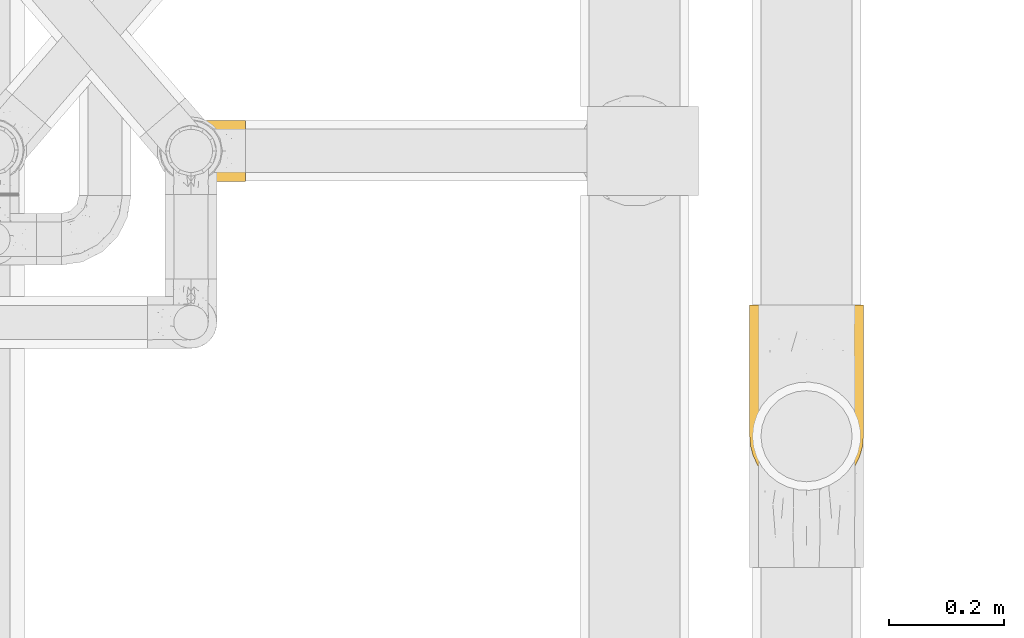
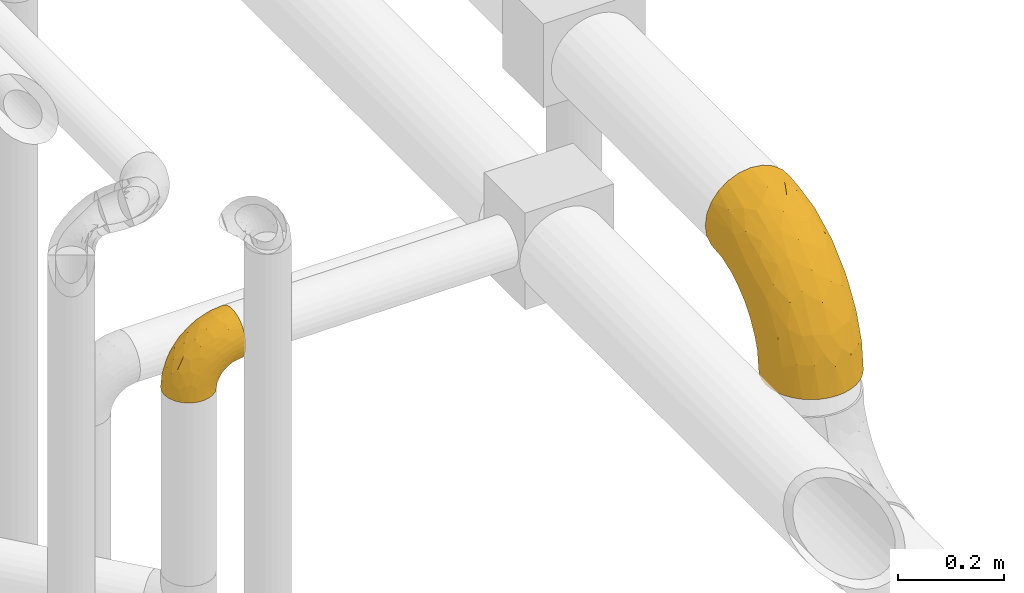
# One storey, part 197 of 827: 2 coverings.
"""IFC2X3 building model written with IfcOpenShell, lengths in millimetres."""

from ifc_helpers import new_model, entity, si_unit, converted_unit, derived_unit, direction, frame, origin, place, context, subcontext, project, spatial, faceted_brep, element, save


model = new_model("IFC2X3")

# Units and contexts
model_context = context("Model", 3, precision=0.01, world=origin(), true_north=direction((6.12303176911189e-17, 1.0)))
body_context = subcontext(model_context, "Body", "Model", "MODEL_VIEW")
ifc_project = project(units=[si_unit("LENGTHUNIT", "METRE", prefix="MILLI"), si_unit("AREAUNIT", "SQUARE_METRE"), si_unit("VOLUMEUNIT", "CUBIC_METRE"), converted_unit("PLANEANGLEUNIT", "DEGREE", entity("IfcRatioMeasure", 0.0174532925199433), si_unit("PLANEANGLEUNIT", "RADIAN"), dimensions=[0, 0, 0, 0, 0, 0, 0]), si_unit("MASSUNIT", "GRAM", prefix="KILO"), derived_unit("MASSDENSITYUNIT", [(si_unit("MASSUNIT", "GRAM", prefix="KILO"), 1), (si_unit("LENGTHUNIT", "METRE"), -3)]), derived_unit("MOMENTOFINERTIAUNIT", [(si_unit("LENGTHUNIT", "METRE"), 4)]), si_unit("TIMEUNIT", "SECOND"), si_unit("FREQUENCYUNIT", "HERTZ"), si_unit("THERMODYNAMICTEMPERATUREUNIT", "DEGREE_CELSIUS"), derived_unit("THERMALTRANSMITTANCEUNIT", [(si_unit("MASSUNIT", "GRAM", prefix="KILO"), 1), (si_unit("THERMODYNAMICTEMPERATUREUNIT", "KELVIN"), -1), (si_unit("TIMEUNIT", "SECOND"), -3)]), derived_unit("VOLUMETRICFLOWRATEUNIT", [(si_unit("LENGTHUNIT", "METRE"), 3), (si_unit("TIMEUNIT", "SECOND"), -1)]), derived_unit("MASSFLOWRATEUNIT", [(si_unit("MASSUNIT", "GRAM", prefix="KILO"), 1), (si_unit("TIMEUNIT", "SECOND"), -1)]), derived_unit("ROTATIONALFREQUENCYUNIT", [(si_unit("TIMEUNIT", "SECOND"), -1)]), si_unit("ELECTRICCURRENTUNIT", "AMPERE"), si_unit("ELECTRICVOLTAGEUNIT", "VOLT"), si_unit("POWERUNIT", "WATT"), si_unit("FORCEUNIT", "NEWTON", prefix="KILO"), si_unit("ILLUMINANCEUNIT", "LUX"), si_unit("LUMINOUSFLUXUNIT", "LUMEN"), si_unit("LUMINOUSINTENSITYUNIT", "CANDELA"), derived_unit("USERDEFINED", [(si_unit("MASSUNIT", "GRAM", prefix="KILO"), -1), (si_unit("LENGTHUNIT", "METRE"), -2), (si_unit("TIMEUNIT", "SECOND"), 3), (si_unit("LUMINOUSFLUXUNIT", "LUMEN"), 1)]), derived_unit("LINEARVELOCITYUNIT", [(si_unit("LENGTHUNIT", "METRE"), 1), (si_unit("TIMEUNIT", "SECOND"), -1)]), si_unit("PRESSUREUNIT", "PASCAL"), derived_unit("USERDEFINED", [(si_unit("LENGTHUNIT", "METRE"), -2), (si_unit("MASSUNIT", "GRAM", prefix="KILO"), 1), (si_unit("TIMEUNIT", "SECOND"), -2)]), derived_unit("LINEARFORCEUNIT", [(si_unit("MASSUNIT", "GRAM", prefix="KILO"), 1), (si_unit("LENGTHUNIT", "METRE"), 1), (si_unit("TIMEUNIT", "SECOND"), -2), (si_unit("LENGTHUNIT", "METRE"), -1)]), derived_unit("PLANARFORCEUNIT", [(si_unit("MASSUNIT", "GRAM", prefix="KILO"), 1), (si_unit("LENGTHUNIT", "METRE"), 1), (si_unit("TIMEUNIT", "SECOND"), -2), (si_unit("LENGTHUNIT", "METRE"), -2)])], contexts=[model_context])

# Site, building, storey
site_placement = place(None, origin())
site = spatial("IfcSite", under=ifc_project, at=site_placement, CompositionType="ELEMENT")
building_placement = place(site_placement, origin())
building = spatial("IfcBuilding", under=site, at=building_placement, CompositionType="ELEMENT")
storey_placement = place(building_placement, frame((0.0, 0.0, 28200.0)))
storey = spatial("IfcBuildingStorey", under=building, at=storey_placement, Name="08", CompositionType="ELEMENT", Elevation=28200.0)

# Coverings
covering_1_placement = place(storey_placement, frame((37947.55, 9481.97, 2769.4)))
element("IfcCovering", 1, at=covering_1_placement, inside=storey, Name=":ADSK_", ObjectType=":ADSK_", PredefinedType="INSULATION", context=body_context, shape_type="Brep", body=[
    faceted_brep([(193.91, 66.83, 1.6), (186.61, 51.17, 1.6), (176.69, 37.01, 1.6), (164.47, 24.79, 1.6), (150.31, 14.87, 1.6), (134.65, 7.57, 1.6), (117.95, 3.1, 1.6), (100.75, 1.6, 1.6), (83.53, 3.1, 1.6), (66.83, 7.58, 1.6), (51.17, 14.88, 1.6), (37.01, 24.8, 1.6), (24.79, 37.02, 1.6), (14.87, 51.18, 1.6), (7.57, 66.84, 1.6), (3.1, 83.54, 1.6), (1.6, 100.75, 1.6), (3.1, 117.96, 1.6), (7.58, 134.66, 1.6), (14.88, 150.32, 1.6), (24.8, 164.48, 1.6), (37.02, 176.7, 1.6), (51.18, 186.62, 1.6), (66.84, 193.92, 1.6), (83.54, 198.39, 1.6), (100.75, 199.9, 1.6), (117.96, 198.39, 1.6), (134.66, 193.91, 1.6), (150.32, 186.61, 1.6), (164.48, 176.69, 1.6), (176.7, 164.47, 1.6), (186.62, 150.31, 1.6), (193.92, 134.65, 1.6), (198.39, 117.95, 1.6), (199.9, 100.75, 1.6), (198.39, 83.53, 1.6), (75.08, 329.75, 134.82), (51.17, 329.75, 144.73), (30.64, 329.75, 160.49), (14.88, 329.75, 181.02), (4.97, 329.75, 204.93), (1.6, 329.75, 230.6), (4.97, 329.75, 256.26), (14.88, 329.75, 280.17), (30.64, 329.75, 300.7), (51.17, 329.75, 316.46), (75.08, 329.75, 326.37), (100.75, 329.75, 329.75), (126.41, 329.75, 326.37), (150.32, 329.75, 316.46), (170.85, 329.75, 300.7), (186.61, 329.75, 280.17), (196.52, 329.75, 256.26), (199.9, 329.75, 230.6), (196.52, 329.75, 204.93), (186.61, 329.75, 181.02), (170.85, 329.75, 160.49), (150.32, 329.75, 144.73), (126.41, 329.75, 134.82), (100.75, 329.75, 131.45), (126.94, 238.01, 312.99), (100.75, 265.73, 323.44), (100.75, 204.17, 304.77), (187.36, 58.91, 60.87), (132.83, 79.76, 205.84), (154.78, 132.21, 243.27), (134.44, 129.24, 253.87), (100.75, 97.71, 233.63), (197.98, 186.17, 204.27), (199.9, 150.71, 144.37), (199.9, 186.97, 180.63), (144.66, 183.03, 283.61), (123.78, 175.7, 288.26), (194.92, 78.89, 69.96), (175.07, 219.35, 274.76), (169.05, 164.59, 253.08), (182.08, 159.21, 230.82), (100.75, 147.43, 274.44), (157.56, 82.35, 188.83), (152.71, 44.46, 131.44), (171.44, 66.34, 142.07), (100.75, 56.9, 183.91), (140.35, 18.29, 74.6), (134.18, 35.26, 132.68), (119.92, 17.04, 94.72), (177.56, 280.46, 289.09), (158.32, 255.09, 302.19), (197.35, 236.53, 235.0), (100.75, 7.9, 65.61), (100.75, 26.57, 127.17), (189.12, 239.55, 260.27), (186.57, 77.16, 119.28), (142.79, 272.89, 315.28), (192.12, 179.84, 223.14), (186.94, 119.6, 183.59), (172.01, 119.08, 212.26), (196.08, 116.35, 143.44), (199.9, 230.39, 207.92), (199.9, 123.42, 100.95), (168.01, 36.91, 74.78), (161.18, 202.68, 281.73), (199.9, 278.79, 224.85), (199.9, 106.49, 52.55), (167.26, 279.85, 148.84), (180.73, 233.31, 142.09), (164.51, 248.07, 131.06), (195.96, 282.45, 197.3), (100.75, 204.32, 35.2), (129.57, 200.89, 38.85), (191.17, 221.48, 155.69), (193.22, 193.12, 138.22), (184.18, 206.15, 126.11), (197.62, 200.63, 164.53), (197.04, 234.54, 183.55), (194.43, 138.52, 47.01), (171.77, 216.73, 114.61), (142.9, 222.16, 90.01), (139.29, 244.97, 110.04), (156.26, 229.98, 109.35), (163.37, 186.39, 52.51), (100.75, 264.82, 114.05), (100.75, 296.14, 127.02), (124.57, 277.3, 123.55), (183.44, 294.68, 172.33), (148.24, 273.95, 132.14), (191.62, 174.02, 109.3), (177.88, 186.35, 86.6), (100.75, 217.29, 66.52), (141.27, 305.12, 137.9), (164.45, 198.94, 81.01), (119.01, 249.34, 105.71), (100.75, 237.93, 93.41), (147.34, 191.69, 32.55), (197.55, 152.36, 109.37), (189.81, 160.25, 76.79), (124.57, 224.79, 82.88), (149.54, 201.49, 64.13), (176.09, 170.92, 44.65), (185.6, 154.96, 33.7), (198.45, 174.17, 145.76), (197.84, 136.48, 81.0), (187.75, 253.47, 166.23), (36.99, 248.07, 131.06), (34.23, 279.84, 148.84), (53.25, 273.95, 132.14), (5.53, 282.45, 197.3), (1.6, 230.39, 207.92), (1.6, 278.79, 224.85), (82.48, 249.34, 105.71), (13.74, 253.46, 166.23), (18.05, 294.68, 172.33), (76.93, 224.79, 82.88), (20.76, 233.3, 142.08), (10.33, 221.48, 155.68), (3.36, 121.48, 31.12), (76.93, 277.3, 123.55), (71.93, 200.89, 38.84), (1.6, 123.42, 100.95), (7.06, 138.53, 47.02), (1.6, 106.49, 52.55), (48.1, 299.03, 143.28), (62.21, 244.97, 110.04), (58.59, 222.16, 90.01), (45.24, 230.0, 109.36), (23.62, 186.36, 86.6), (9.86, 174.01, 109.32), (17.31, 206.14, 126.08), (25.4, 170.94, 44.66), (11.69, 160.27, 76.81), (51.96, 201.5, 64.13), (1.6, 186.97, 180.63), (3.87, 200.62, 164.52), (3.05, 174.17, 145.75), (38.14, 186.4, 52.5), (37.05, 198.95, 81.01), (4.45, 234.52, 183.55), (54.17, 191.7, 32.55), (14.84, 155.33, 44.0), (5.35, 143.22, 79.09), (3.94, 152.35, 109.36), (8.28, 193.12, 138.22), (29.73, 216.74, 114.6), (1.6, 150.71, 144.37), (4.14, 236.53, 235.0), (3.51, 186.17, 204.27), (9.37, 179.84, 223.14), (74.55, 238.01, 312.99), (6.56, 78.9, 69.96), (14.92, 77.18, 119.29), (14.55, 119.62, 183.6), (5.41, 116.35, 143.44), (30.04, 66.35, 142.06), (67.05, 129.25, 253.88), (12.37, 239.55, 260.27), (57.97, 232.94, 304.98), (43.17, 255.09, 302.19), (56.83, 183.03, 283.61), (23.93, 280.45, 289.09), (26.42, 219.35, 274.76), (68.66, 79.76, 205.84), (67.31, 35.26, 132.69), (29.48, 119.08, 212.26), (43.93, 82.34, 188.81), (77.71, 175.7, 288.27), (39.51, 182.77, 271.11), (61.13, 18.3, 74.6), (46.71, 132.19, 243.26), (26.88, 166.31, 247.35), (33.47, 36.91, 74.77), (14.12, 58.92, 60.87), (81.56, 17.04, 94.72), (48.77, 44.46, 131.42)], [[[0, 1, 2, 3, 4, 5, 6, 7, 8, 9, 10, 11, 12, 13, 14, 15, 16, 17, 18, 19, 20, 21, 22, 23, 24, 25, 26, 27, 28, 29, 30, 31, 32, 33, 34, 35]], [[36, 37, 38, 39, 40, 41, 42, 43, 44, 45, 46, 47, 48, 49, 50, 51, 52, 53, 54, 55, 56, 57, 58, 59]], [[60, 61, 62]], [[61, 48, 47]], [[63, 2, 1]], [[64, 65, 66]], [[64, 66, 67]], [[68, 69, 70]], [[71, 72, 66]], [[73, 0, 35]], [[74, 75, 76]], [[77, 72, 62]], [[78, 79, 80]], [[64, 67, 81]], [[82, 83, 84]], [[51, 50, 85]], [[86, 50, 49]], [[53, 52, 87]], [[74, 85, 86]], [[88, 84, 89]], [[74, 76, 90]], [[73, 91, 63]], [[92, 48, 60]], [[93, 68, 87]], [[94, 95, 80]], [[94, 91, 96]], [[87, 68, 97]], [[96, 98, 69]], [[82, 99, 79]], [[99, 63, 80]], [[87, 90, 93]], [[78, 65, 64]], [[84, 6, 5]], [[99, 82, 3]], [[52, 90, 87]], [[82, 84, 5]], [[92, 86, 49]], [[3, 82, 4]], [[74, 100, 75]], [[88, 7, 6]], [[87, 97, 101]], [[99, 3, 2]], [[98, 96, 73]], [[98, 73, 102]], [[4, 82, 5]], [[34, 102, 35]], [[53, 87, 101]], [[84, 83, 89]], [[71, 86, 92]], [[80, 79, 99]], [[102, 73, 35]], [[96, 69, 68]], [[96, 91, 73]], [[73, 63, 0]], [[63, 99, 2]], [[52, 51, 90]], [[48, 61, 60]], [[83, 81, 89]], [[85, 90, 51]], [[65, 75, 100]], [[6, 84, 88]], [[82, 79, 83]], [[94, 80, 91]], [[78, 80, 95]], [[79, 64, 83]], [[81, 83, 64]], [[65, 78, 95]], [[64, 79, 78]], [[75, 65, 95]], [[65, 71, 66]], [[72, 71, 60]], [[67, 66, 77]], [[62, 72, 60]], [[77, 66, 72]], [[96, 93, 94]], [[76, 94, 93]], [[96, 68, 93]], [[97, 68, 70]], [[63, 91, 80]], [[0, 63, 1]], [[76, 75, 95]], [[74, 86, 100]], [[94, 76, 95]], [[76, 93, 90]], [[86, 71, 100]], [[65, 100, 71]], [[86, 85, 50]], [[90, 85, 74]], [[48, 92, 49]], [[71, 92, 60]], [[103, 104, 105]], [[54, 53, 101]], [[54, 101, 106]], [[26, 107, 108]], [[109, 110, 111]], [[70, 112, 113]], [[106, 97, 113]], [[102, 32, 114]], [[103, 57, 56]], [[104, 115, 105]], [[116, 117, 118]], [[29, 28, 119]], [[120, 121, 122]], [[55, 123, 56]], [[124, 117, 122]], [[125, 126, 111]], [[127, 108, 107]], [[124, 128, 103]], [[105, 117, 124]], [[121, 59, 58]], [[119, 129, 126]], [[117, 130, 122]], [[131, 120, 130]], [[119, 28, 132]], [[133, 134, 125]], [[108, 135, 136]], [[30, 137, 138]], [[58, 57, 128]], [[114, 32, 31]], [[114, 138, 134]], [[133, 125, 139]], [[34, 33, 102]], [[134, 133, 140]], [[114, 31, 138]], [[106, 55, 54]], [[33, 32, 102]], [[122, 130, 120]], [[121, 58, 122]], [[27, 26, 108]], [[108, 127, 135]], [[25, 107, 26]], [[117, 105, 118]], [[137, 30, 29]], [[127, 131, 135]], [[110, 112, 139]], [[136, 132, 108]], [[56, 123, 103]], [[137, 126, 134]], [[132, 27, 108]], [[131, 130, 135]], [[123, 106, 141]], [[114, 140, 102]], [[135, 130, 117]], [[97, 106, 101]], [[126, 137, 119]], [[126, 115, 111]], [[122, 58, 128]], [[105, 124, 103]], [[104, 103, 141]], [[105, 115, 118]], [[109, 104, 141]], [[111, 115, 104]], [[106, 123, 55]], [[103, 123, 141]], [[129, 118, 115]], [[117, 116, 135]], [[129, 116, 118]], [[136, 135, 116]], [[113, 109, 141]], [[112, 110, 109]], [[106, 113, 141]], [[70, 113, 97]], [[113, 112, 109]], [[139, 70, 69]], [[70, 139, 112]], [[139, 69, 133]], [[69, 98, 133]], [[140, 133, 98]], [[109, 111, 104]], [[111, 110, 125]], [[119, 132, 136]], [[27, 132, 28]], [[119, 136, 129]], [[29, 119, 137]], [[129, 136, 116]], [[115, 126, 129]], [[126, 125, 134]], [[139, 125, 110]], [[30, 138, 31]], [[134, 138, 137]], [[103, 128, 57]], [[122, 128, 124]], [[102, 140, 98]], [[134, 140, 114]], [[142, 143, 144]], [[145, 146, 147]], [[120, 131, 148]], [[149, 150, 143]], [[127, 151, 131]], [[152, 153, 149]], [[59, 121, 36]], [[17, 154, 18]], [[120, 148, 155]], [[156, 151, 127]], [[157, 158, 159]], [[36, 144, 160]], [[161, 162, 163]], [[164, 165, 166]], [[39, 145, 40]], [[41, 40, 147]], [[164, 167, 168]], [[150, 39, 38]], [[156, 169, 151]], [[40, 145, 147]], [[36, 155, 144]], [[38, 37, 160]], [[170, 171, 172]], [[120, 155, 121]], [[151, 161, 148]], [[173, 174, 169]], [[24, 23, 156]], [[145, 149, 175]], [[150, 145, 39]], [[24, 107, 25]], [[23, 22, 176]], [[177, 20, 19]], [[20, 167, 21]], [[175, 149, 153]], [[164, 174, 173]], [[167, 173, 21]], [[156, 127, 107]], [[177, 158, 178]], [[157, 179, 178]], [[165, 172, 180]], [[19, 18, 158]], [[181, 142, 163]], [[177, 168, 167]], [[152, 149, 143]], [[17, 16, 159]], [[173, 169, 176]], [[107, 24, 156]], [[17, 159, 154]], [[143, 142, 152]], [[172, 179, 182]], [[36, 121, 155]], [[169, 156, 176]], [[164, 168, 165]], [[144, 155, 161]], [[159, 158, 154]], [[158, 18, 154]], [[151, 148, 131]], [[155, 148, 161]], [[163, 142, 144]], [[160, 144, 143]], [[163, 144, 161]], [[142, 181, 152]], [[181, 166, 152]], [[152, 166, 153]], [[143, 150, 38]], [[145, 150, 149]], [[162, 161, 151]], [[163, 162, 174]], [[151, 169, 162]], [[174, 162, 169]], [[180, 171, 153]], [[175, 170, 146]], [[175, 153, 171]], [[145, 175, 146]], [[172, 171, 180]], [[175, 171, 170]], [[179, 165, 168]], [[170, 172, 182]], [[178, 179, 168]], [[157, 182, 179]], [[164, 166, 181]], [[153, 166, 180]], [[23, 176, 156]], [[22, 21, 173]], [[173, 176, 22]], [[164, 173, 167]], [[164, 181, 174]], [[163, 174, 181]], [[172, 165, 179]], [[165, 180, 166]], [[20, 177, 167]], [[19, 158, 177]], [[38, 160, 143]], [[36, 160, 37]], [[177, 178, 168]], [[157, 178, 158]], [[183, 184, 185]], [[45, 186, 46]], [[61, 46, 186]], [[183, 41, 147]], [[146, 170, 184]], [[62, 61, 186]], [[187, 157, 159]], [[188, 189, 190]], [[188, 191, 189]], [[182, 190, 184]], [[192, 67, 77]], [[193, 183, 185]], [[194, 45, 195]], [[194, 195, 196]], [[61, 47, 46]], [[42, 193, 43]], [[44, 43, 197]], [[197, 193, 198]], [[81, 199, 200]], [[201, 191, 202]], [[44, 197, 195]], [[196, 192, 203]], [[15, 187, 159]], [[62, 186, 203]], [[183, 193, 42]], [[190, 185, 184]], [[190, 182, 157]], [[204, 195, 198]], [[205, 10, 9]], [[206, 204, 207]], [[159, 16, 15]], [[14, 187, 15]], [[12, 208, 209]], [[41, 183, 42]], [[208, 12, 11]], [[44, 195, 45]], [[185, 207, 193]], [[13, 209, 14]], [[188, 190, 187]], [[205, 210, 200]], [[81, 67, 199]], [[208, 11, 205]], [[196, 206, 192]], [[88, 89, 210]], [[191, 188, 209]], [[205, 11, 10]], [[210, 8, 88]], [[9, 8, 210]], [[7, 88, 8]], [[191, 208, 211]], [[191, 209, 208]], [[208, 205, 211]], [[200, 211, 205]], [[146, 183, 147]], [[207, 201, 206]], [[188, 187, 209]], [[187, 190, 157]], [[202, 206, 201]], [[89, 81, 200]], [[210, 205, 9]], [[202, 191, 211]], [[189, 191, 201]], [[200, 210, 89]], [[199, 211, 200]], [[211, 199, 202]], [[199, 192, 206]], [[199, 206, 202]], [[204, 206, 196]], [[67, 192, 199]], [[203, 186, 194]], [[192, 77, 203]], [[62, 203, 77]], [[207, 189, 201]], [[185, 190, 189]], [[146, 184, 183]], [[184, 170, 182]], [[14, 209, 187]], [[209, 13, 12]], [[195, 204, 196]], [[204, 198, 207]], [[193, 207, 198]], [[189, 207, 185]], [[193, 197, 43]], [[195, 197, 198]], [[203, 194, 196]], [[45, 194, 186]]]),
])
covering_2_placement = place(storey_placement, frame((36920.39, 10025.56, 2803.31)))
element("IfcCovering", 2, at=covering_2_placement, inside=storey, Name=":ADSK_", ObjectType=":ADSK_", PredefinedType="INSULATION", context=body_context, shape_type="Brep", body=[
    faceted_brep([(149.64, 107.7, 96.6), (149.64, 106.36, 108.41), (149.64, 102.44, 119.62), (149.64, 96.11, 129.68), (149.64, 87.71, 138.08), (149.64, 77.65, 144.4), (149.64, 66.44, 148.32), (149.64, 54.65, 149.65), (149.64, 42.84, 148.31), (149.64, 31.62, 144.39), (149.64, 21.56, 138.06), (149.64, 13.16, 129.66), (149.64, 6.84, 119.6), (149.64, 2.92, 108.39), (149.64, 1.6, 96.6), (149.64, 2.93, 84.79), (149.64, 6.85, 73.57), (149.64, 13.18, 63.51), (149.65, 21.58, 55.11), (149.65, 31.64, 48.79), (149.65, 42.85, 44.87), (149.65, 54.65, 43.55), (149.65, 66.46, 44.88), (149.65, 77.67, 48.8), (149.65, 87.73, 55.13), (149.64, 96.13, 63.53), (149.64, 102.45, 73.59), (149.64, 106.37, 84.8), (105.89, 40.91, 1.6), (100.59, 28.12, 1.6), (92.16, 17.13, 1.6), (81.17, 8.7, 1.6), (68.38, 3.4, 1.6), (54.65, 1.6, 1.6), (40.91, 3.4, 1.6), (28.12, 8.7, 1.6), (17.13, 17.13, 1.6), (8.7, 28.12, 1.6), (3.4, 40.91, 1.6), (1.6, 54.65, 1.6), (3.4, 68.38, 1.6), (8.7, 81.17, 1.6), (17.13, 92.16, 1.6), (28.12, 100.59, 1.6), (40.91, 105.89, 1.6), (54.65, 107.7, 1.6), (68.38, 105.89, 1.6), (81.17, 100.59, 1.6), (92.16, 92.16, 1.6), (100.59, 81.17, 1.6), (105.89, 68.38, 1.6), (107.7, 54.65, 1.6), (14.05, 85.53, 27.97), (9.45, 73.42, 37.09), (22.36, 83.77, 58.27), (4.7, 64.22, 27.13), (6.64, 54.65, 39.91), (81.47, 96.72, 109.11), (56.83, 93.36, 94.41), (64.02, 84.47, 110.93), (34.04, 71.37, 89.69), (21.43, 54.65, 75.62), (44.96, 54.65, 106.28), (49.8, 103.47, 60.12), (35.43, 100.91, 41.41), (42.1, 99.1, 63.22), (43.59, 105.43, 32.05), (57.88, 106.79, 52.13), (91.8, 89.81, 123.27), (88.01, 79.59, 129.32), (115.65, 81.29, 138.3), (18.94, 74.01, 62.95), (12.83, 64.14, 55.89), (24.96, 94.75, 37.4), (111.33, 54.65, 144.6), (113.8, 70.74, 142.66), (60.89, 68.3, 117.85), (86.24, 66.05, 134.01), (65.84, 100.73, 89.25), (124.58, 106.78, 103.34), (121.36, 103.6, 113.52), (72.79, 107.7, 57.43), (66.04, 107.7, 44.19), (59.29, 107.7, 30.95), (73.26, 106.07, 77.98), (121.69, 90.59, 132.66), (109.82, 97.43, 121.52), (40.11, 84.51, 86.93), (36.57, 93.3, 68.4), (93.81, 107.7, 78.45), (83.3, 107.7, 67.94), (136.6, 107.7, 94.53), (120.29, 107.7, 91.95), (99.11, 106.79, 93.36), (107.05, 107.7, 85.2), (91.12, 103.47, 101.45), (75.62, 54.65, 129.81), (56.97, 107.7, 16.27), (126.65, 76.99, 42.46), (116.55, 84.28, 40.4), (120.09, 91.11, 49.71), (76.06, 106.26, 39.4), (83.7, 102.6, 31.26), (71.88, 106.08, 27.7), (66.92, 106.56, 16.7), (110.43, 105.36, 70.67), (121.31, 106.74, 81.69), (81.0, 101.59, 16.68), (113.32, 54.65, 22.57), (111.09, 54.65, 14.26), (109.14, 67.71, 17.68), (95.86, 91.36, 19.58), (99.07, 94.33, 33.49), (106.92, 87.1, 33.01), (131.39, 65.84, 40.69), (136.98, 54.65, 40.15), (128.67, 54.65, 37.92), (117.07, 68.92, 31.04), (96.39, 100.82, 45.29), (106.61, 79.83, 23.55), (103.72, 77.13, 11.36), (92.14, 105.9, 59.1), (107.13, 101.53, 57.42), (98.03, 106.72, 68.96), (88.38, 97.75, 20.38), (130.66, 103.08, 72.46), (135.45, 106.39, 83.66), (123.57, 98.1, 60.66), (137.75, 95.02, 61.01), (133.2, 86.9, 51.85), (138.8, 74.42, 46.07), (120.99, 54.65, 30.25), (84.53, 105.28, 46.65), (108.72, 92.87, 43.0), (95.86, 17.93, 19.58), (130.67, 6.22, 72.44), (109.13, 41.58, 17.67), (93.81, 1.6, 78.45), (98.02, 2.57, 68.97), (110.43, 3.94, 70.65), (131.4, 43.46, 40.69), (126.66, 32.32, 42.45), (117.08, 40.38, 31.04), (108.74, 16.44, 42.99), (96.31, 8.47, 45.18), (99.11, 15.01, 33.46), (123.58, 11.21, 60.64), (107.12, 7.78, 57.37), (72.79, 1.6, 57.43), (66.04, 1.6, 44.19), (76.07, 3.04, 39.35), (56.97, 1.6, 16.27), (66.92, 2.73, 16.7), (120.29, 1.6, 91.95), (107.05, 1.6, 85.2), (121.26, 2.55, 81.68), (84.46, 3.98, 46.68), (83.7, 6.69, 31.26), (81.0, 7.7, 16.68), (71.88, 3.21, 27.7), (137.76, 14.28, 60.99), (133.21, 22.42, 51.84), (116.58, 25.02, 40.41), (120.1, 18.18, 49.72), (138.81, 34.89, 46.06), (136.6, 1.6, 94.53), (103.72, 32.17, 11.35), (106.96, 22.23, 33.02), (135.44, 2.91, 83.65), (88.38, 11.54, 20.38), (83.3, 1.6, 67.94), (92.12, 3.38, 59.12), (106.6, 29.46, 23.53), (59.29, 1.6, 30.95), (22.36, 25.52, 58.27), (14.05, 23.76, 27.97), (24.96, 14.54, 37.4), (35.43, 8.38, 41.41), (4.71, 45.07, 27.21), (9.45, 35.87, 37.09), (11.79, 45.14, 53.2), (57.88, 2.5, 52.13), (124.57, 2.51, 103.34), (121.37, 5.68, 113.5), (91.12, 5.82, 101.45), (56.83, 15.93, 94.41), (81.48, 12.54, 109.08), (64.05, 24.81, 110.94), (99.11, 2.5, 93.36), (73.26, 3.22, 77.98), (43.59, 3.86, 32.05), (19.5, 35.85, 64.63), (91.8, 19.47, 123.25), (121.7, 18.68, 132.65), (88.04, 29.68, 129.32), (123.34, 27.95, 139.96), (60.89, 40.99, 117.85), (34.04, 37.92, 89.69), (109.85, 11.85, 121.51), (42.1, 10.19, 63.23), (65.78, 8.55, 89.17), (113.81, 38.53, 142.66), (36.57, 15.99, 68.4), (40.12, 24.79, 86.94), (49.8, 5.82, 60.12), (86.08, 40.56, 133.2)], [[[0, 1, 2, 3, 4, 5, 6, 7, 8, 9, 10, 11, 12, 13, 14, 15, 16, 17, 18, 19, 20, 21, 22, 23, 24, 25, 26, 27]], [[28, 29, 30, 31, 32, 33, 34, 35, 36, 37, 38, 39, 40, 41, 42, 43, 44, 45, 46, 47, 48, 49, 50, 51]], [[52, 53, 54]], [[55, 39, 56]], [[57, 58, 59]], [[60, 61, 62]], [[63, 64, 65]], [[66, 63, 67]], [[68, 69, 70]], [[53, 71, 54]], [[41, 40, 53]], [[53, 72, 71]], [[73, 42, 52]], [[42, 41, 52]], [[74, 6, 75]], [[69, 76, 77]], [[43, 73, 64]], [[45, 44, 66]], [[57, 78, 58]], [[1, 79, 80]], [[67, 81, 82, 83]], [[67, 84, 81]], [[2, 1, 80]], [[3, 85, 4]], [[86, 85, 3]], [[42, 73, 43]], [[6, 5, 75]], [[3, 2, 86]], [[70, 4, 85]], [[6, 74, 7]], [[68, 85, 86]], [[66, 64, 63]], [[60, 59, 87]], [[54, 87, 88]], [[76, 60, 62]], [[84, 89, 90, 81]], [[79, 0, 91, 92]], [[77, 74, 75]], [[93, 92, 94, 89]], [[80, 86, 2]], [[40, 55, 53]], [[76, 59, 60]], [[93, 84, 95]], [[76, 62, 96]], [[55, 72, 53]], [[70, 5, 4]], [[75, 70, 69]], [[78, 84, 63]], [[93, 79, 92]], [[95, 86, 80]], [[77, 76, 96]], [[59, 69, 68]], [[57, 68, 86]], [[68, 57, 59]], [[59, 58, 87]], [[76, 69, 59]], [[88, 87, 58]], [[87, 54, 71]], [[86, 95, 57]], [[78, 57, 95]], [[84, 78, 95]], [[78, 63, 65]], [[58, 78, 65]], [[54, 88, 73]], [[84, 93, 89]], [[79, 95, 80]], [[79, 93, 95]], [[0, 79, 1]], [[66, 83, 97, 45]], [[84, 67, 63]], [[83, 66, 67]], [[64, 44, 43]], [[64, 66, 44]], [[65, 73, 88]], [[53, 52, 41]], [[73, 52, 54]], [[73, 65, 64]], [[65, 88, 58]], [[39, 55, 40]], [[72, 55, 56]], [[56, 61, 72]], [[60, 72, 61]], [[72, 60, 71]], [[87, 71, 60]], [[5, 70, 75]], [[68, 70, 85]], [[74, 77, 96]], [[69, 77, 75]], [[98, 99, 100]], [[46, 45, 97]], [[101, 102, 103]], [[103, 104, 83]], [[105, 94, 106]], [[107, 103, 102]], [[108, 109, 51, 110]], [[111, 112, 113]], [[114, 115, 116]], [[47, 104, 107]], [[110, 117, 108]], [[49, 48, 111]], [[102, 118, 112]], [[119, 120, 111]], [[50, 49, 120]], [[121, 122, 118]], [[105, 123, 89]], [[124, 48, 107]], [[26, 25, 125]], [[121, 81, 90]], [[117, 119, 99]], [[27, 26, 126]], [[0, 27, 91]], [[105, 125, 127]], [[110, 51, 50]], [[25, 128, 125]], [[22, 21, 115]], [[129, 98, 100]], [[126, 91, 27]], [[128, 129, 127]], [[122, 123, 105]], [[114, 117, 98]], [[23, 22, 130]], [[24, 128, 25]], [[129, 24, 23]], [[125, 106, 126]], [[115, 114, 22]], [[130, 129, 23]], [[114, 98, 130]], [[117, 116, 131, 108]], [[99, 119, 113]], [[122, 121, 123]], [[92, 126, 106]], [[105, 127, 122]], [[132, 121, 118]], [[114, 130, 22]], [[129, 130, 98]], [[50, 120, 110]], [[129, 128, 24]], [[125, 128, 127]], [[125, 126, 26]], [[91, 126, 92]], [[105, 89, 94]], [[105, 106, 125]], [[94, 92, 106]], [[100, 122, 127]], [[118, 122, 133]], [[112, 118, 133]], [[132, 118, 102]], [[132, 102, 101]], [[81, 121, 132]], [[82, 103, 83]], [[132, 101, 81]], [[104, 47, 46]], [[124, 107, 102]], [[48, 47, 107]], [[113, 112, 133]], [[112, 111, 124]], [[99, 113, 133]], [[111, 113, 119]], [[99, 133, 100]], [[117, 99, 98]], [[122, 100, 133]], [[127, 129, 100]], [[103, 82, 101]], [[81, 101, 82]], [[112, 124, 102]], [[48, 124, 111]], [[104, 103, 107]], [[46, 97, 104]], [[111, 120, 49]], [[83, 104, 97]], [[110, 120, 119]], [[117, 110, 119]], [[116, 117, 114]], [[89, 123, 90]], [[90, 123, 121]], [[30, 29, 134]], [[17, 16, 135]], [[51, 109, 108, 136]], [[137, 138, 139]], [[140, 141, 142]], [[143, 144, 145]], [[146, 139, 147]], [[148, 149, 150]], [[151, 32, 152]], [[153, 154, 155]], [[156, 150, 157]], [[158, 157, 159]], [[108, 142, 136]], [[31, 158, 152]], [[160, 161, 18]], [[162, 163, 143]], [[140, 142, 116]], [[142, 141, 162]], [[20, 164, 140]], [[20, 140, 115]], [[15, 14, 165]], [[160, 18, 17]], [[141, 164, 161]], [[19, 18, 161]], [[20, 115, 21]], [[28, 166, 29]], [[135, 139, 146]], [[141, 163, 162]], [[135, 146, 160]], [[143, 167, 162]], [[29, 166, 134]], [[116, 142, 108, 131]], [[165, 153, 168]], [[16, 15, 168]], [[168, 135, 16]], [[138, 147, 139]], [[158, 169, 157]], [[20, 19, 164]], [[116, 115, 140]], [[145, 167, 143]], [[135, 160, 17]], [[168, 153, 155]], [[138, 170, 171]], [[157, 144, 156]], [[147, 144, 143]], [[161, 164, 19]], [[140, 164, 141]], [[142, 172, 136]], [[136, 172, 166]], [[161, 160, 146]], [[165, 168, 15]], [[155, 139, 135]], [[139, 154, 137]], [[168, 155, 135]], [[139, 155, 154]], [[144, 147, 171]], [[163, 147, 143]], [[156, 144, 171]], [[157, 169, 145]], [[171, 148, 156]], [[173, 159, 149]], [[159, 157, 150]], [[152, 159, 173]], [[159, 152, 158]], [[31, 30, 158]], [[169, 30, 134]], [[157, 145, 144]], [[167, 134, 172]], [[134, 167, 145]], [[172, 142, 162]], [[162, 167, 172]], [[163, 141, 161]], [[161, 146, 163]], [[147, 163, 146]], [[148, 150, 156]], [[149, 159, 150]], [[30, 169, 158]], [[145, 169, 134]], [[151, 33, 32]], [[31, 152, 32]], [[152, 173, 151]], [[28, 51, 136]], [[134, 166, 172]], [[28, 136, 166]], [[147, 138, 171]], [[170, 138, 137]], [[170, 148, 171]], [[174, 175, 176]], [[35, 34, 177]], [[178, 179, 180]], [[181, 173, 149, 148]], [[182, 183, 184]], [[185, 186, 187]], [[188, 189, 137]], [[190, 33, 151, 173]], [[191, 179, 174]], [[34, 190, 177]], [[39, 38, 178]], [[192, 193, 194]], [[10, 9, 195]], [[175, 179, 37]], [[38, 37, 179]], [[35, 176, 36]], [[196, 62, 197]], [[181, 190, 173]], [[37, 36, 175]], [[183, 12, 198]], [[189, 148, 170, 137]], [[185, 199, 200]], [[9, 8, 201]], [[202, 185, 203]], [[14, 13, 182]], [[200, 184, 186]], [[183, 13, 12]], [[181, 189, 204]], [[200, 189, 184]], [[11, 198, 12]], [[187, 203, 185]], [[195, 9, 201]], [[205, 196, 194]], [[62, 61, 197]], [[186, 198, 192]], [[180, 179, 191]], [[8, 7, 74]], [[198, 193, 192]], [[193, 11, 10]], [[194, 193, 195]], [[8, 74, 201]], [[11, 193, 198]], [[205, 74, 96]], [[188, 137, 154, 153]], [[62, 196, 96]], [[56, 178, 180]], [[198, 184, 183]], [[184, 188, 182]], [[203, 197, 191]], [[205, 194, 201]], [[187, 192, 194]], [[192, 187, 186]], [[194, 196, 187]], [[197, 187, 196]], [[197, 203, 187]], [[202, 174, 176]], [[200, 186, 185]], [[184, 198, 186]], [[199, 185, 202]], [[189, 200, 204]], [[174, 202, 203]], [[176, 177, 199]], [[189, 181, 148]], [[190, 181, 204]], [[190, 204, 177]], [[190, 34, 33]], [[188, 153, 182]], [[189, 188, 184]], [[182, 153, 165, 14]], [[183, 182, 13]], [[199, 177, 204]], [[35, 177, 176]], [[176, 175, 36]], [[179, 175, 174]], [[200, 199, 204]], [[176, 199, 202]], [[203, 191, 174]], [[180, 197, 61]], [[197, 180, 191]], [[61, 56, 180]], [[39, 178, 56]], [[38, 179, 178]], [[194, 195, 201]], [[10, 195, 193]], [[74, 205, 201]], [[96, 196, 205]]]),
])

save(model, "model.ifc")
